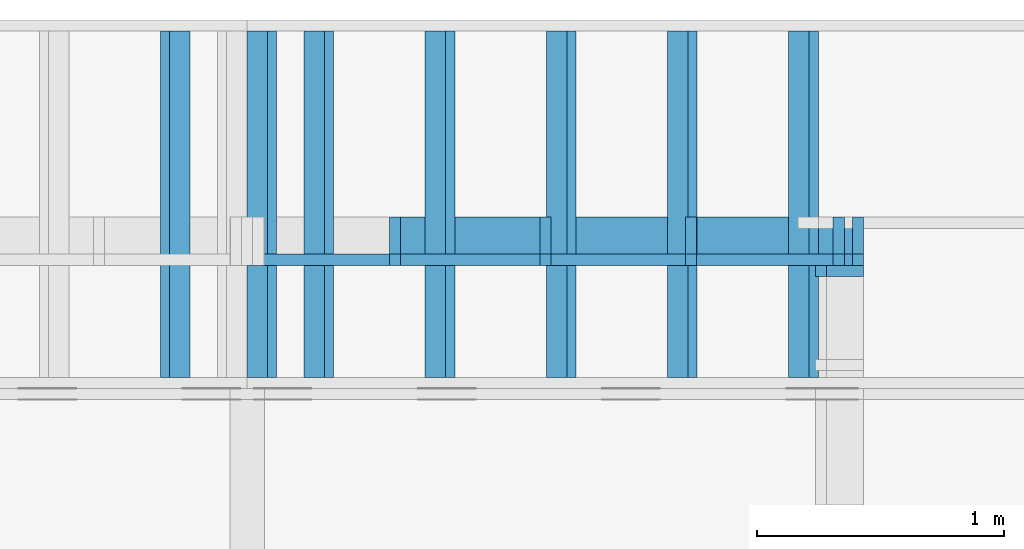
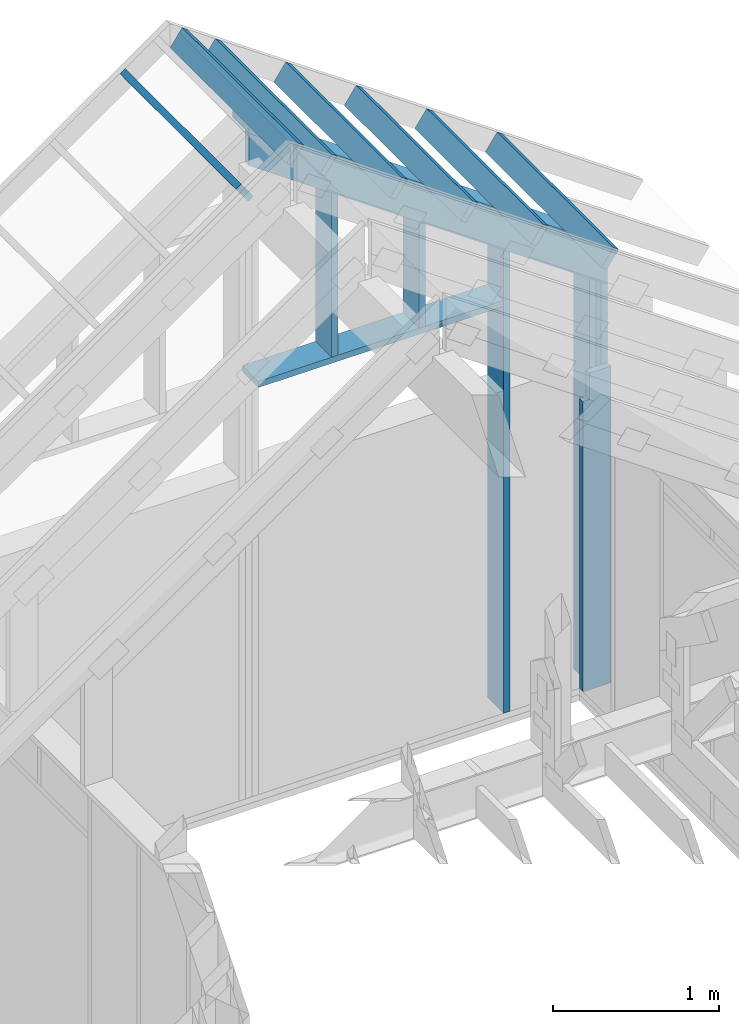
# One storey, part 35 of 70: 16 members, 4 elements without a shape of their own.
"""IFC2X3 building model written with IfcOpenShell, lengths in millimetres."""

from ifc_helpers import new_model, si_unit, frame, origin, origin_with_axes, origin_2d, place, context, project, spatial, faceted_brep, element, aggregate, save


model = new_model("IFC2X3")

# Units and contexts
model_context = context("Model", 3, precision=1e-05, world=origin())
plan_context = context("Plan", 2, precision=1e-05, world=origin_2d())
ifc_project = project(units=[si_unit("LENGTHUNIT", "METRE", prefix="MILLI"), si_unit("AREAUNIT", "SQUARE_METRE"), si_unit("VOLUMEUNIT", "CUBIC_METRE"), si_unit("SOLIDANGLEUNIT", "STERADIAN"), si_unit("PLANEANGLEUNIT", "RADIAN"), si_unit("MASSUNIT", "GRAM"), si_unit("TIMEUNIT", "SECOND"), si_unit("THERMODYNAMICTEMPERATUREUNIT", "DEGREE_CELSIUS"), si_unit("LUMINOUSINTENSITYUNIT", "LUMEN")], contexts=[model_context, plan_context])

# Site, building, storey
site_placement = place(None, origin_with_axes())
site = spatial("IfcSite", under=ifc_project, at=site_placement, CompositionType="ELEMENT")
building_placement = place(site_placement, origin_with_axes())
building = spatial("IfcBuilding", under=site, at=building_placement, Name="Layout 1", CompositionType="ELEMENT")
storey_placement = place(building_placement, origin_with_axes())
storey = spatial("IfcBuildingStorey", under=building, at=storey_placement, Name="Storey 1", CompositionType="ELEMENT", Elevation=0.0)

# Assembly, member
assembly_1_placement = place(storey_placement, frame((12000.0, 0.0, -2470.0), z_axis=(1.0, -6.123031769111886e-17, 6.123031769111886e-17), x_axis=(6.123031769111886e-17, 1.0, 0.0)))
assembly_1 = element("IfcElementAssembly", 1, at=assembly_1_placement, inside=storey, Name="VE5", AssemblyPlace="FACTORY", PredefinedType="NOTDEFINED")
member_1_placement = place(assembly_1_placement, frame((11760.0, 2425.0, -195.00000000000003), z_axis=(0.0, 0.0, 1.0), x_axis=(-1.836909530733566e-16, -1.0, 0.0)))
member_1 = element("IfcMember", 2, at=member_1_placement, Name="S11", context=model_context, shape_type="Brep", body=[
    faceted_brep([(0.0, 45.0, 45.00000000000003), (195.00000000186265, 45.0, 45.00000000000005), (195.00000000186265, 0.0, 45.00000000000005), (0.0, 0.0, 45.00000000000003), (195.00000000186265, -2.1311460639909362e-46, 2.842170943040401e-14), (195.00000000186265, -3.3742366240998114e-31, 45.00000000000003), (195.00000000186265, 45.0, 45.00000000000003), (195.00000000186265, 45.0, 2.842170943040401e-14), (2.7553642961003504e-15, -3.3742366240998114e-31, 45.00000000000003), (1.193991194976818e-14, -1.4621692037765842e-30, 195.00000000000003), (1.7450640541968876e-14, 45.0, 195.00000000000003), (8.266092888301048e-15, 45.0, 45.00000000000003), (2335.0, -4.2891837542628763e-13, 2.842170943040403e-14), (2335.0, -4.1697846347651946e-13, 195.00000000000003), (2.1932538056648764e-30, 1.193991194976818e-14, 195.00000000000003), (5.061354936149717e-31, 2.7553642961003504e-15, 45.00000000000003), (195.00000000186265, -3.306437155354634e-14, 45.00000000000003), (195.00000000186265, -3.5819735849646686e-14, 2.842170943040401e-14), (-1.6871183120499057e-31, 45.0, 45.00000000000003), (-7.310846018882921e-31, 44.999999999999986, 195.00000000000003), (2335.0, 44.999999999999844, 195.00000000000003), (2335.0, 44.99999999999986, 2.8421709430403998e-14), (195.00000000186265, 44.999999999999986, 2.842170943040401e-14), (195.00000000186265, 44.999999999999986, 45.00000000000003), (2335.0, 45.0, 0.0), (2335.0, 45.0, 195.00000000000003), (2335.0, 0.0, 195.00000000000003), (2335.0, 0.0, 0.0), (2335.0, 45.0, 195.00000000000003), (0.0, 45.0, 195.00000000000003), (0.0, 0.0, 195.00000000000003), (2335.0, 0.0, 195.00000000000003), (195.00000000186265, 45.0, 5.2301533330168465e-14), (2335.0, 45.0, 3.143672930479291e-13), (2335.0, 0.0, 3.143672930479291e-13), (195.00000000186265, 0.0, 5.2301533330168465e-14)], [[[0, 1, 2, 3]], [[4, 5, 6, 7]], [[8, 9, 10, 11]], [[12, 13, 14, 15, 16, 17]], [[18, 19, 20, 21, 22, 23]], [[24, 25, 26, 27]], [[28, 29, 30, 31]], [[32, 33, 34, 35]]]),
])
aggregate(assembly_1, [member_1])

# Assembly, members
assembly_2_placement = place(storey_placement, frame((12000.0, 12000.0, -2470.0), z_axis=(1.2246063538223773e-16, 1.0, 6.123031769111886e-17), x_axis=(-1.0, 1.2246063538223773e-16, 0.0)))
assembly_2 = element("IfcElementAssembly", 3, at=assembly_2_placement, inside=storey, Name="VE6", AssemblyPlace="FACTORY", PredefinedType="NOTDEFINED")
member_2_placement = place(assembly_2_placement, frame((2.2737367544323206e-13, 3238.052828134969, -195.00000000000003), z_axis=(0.0, 0.0, 1.0), x_axis=(0.819152044288992, 0.5735764363510458, 0.0)))
member_2 = element("IfcMember", 4, at=member_2_placement, Name="P9", context=model_context, shape_type="Brep", body=[
    faceted_brep([(3083.445811122576, 44.99999999928377, 195.0), (31.509339219794356, 44.99999999928377, 195.0), (0.0, 0.0, 195.0), (3051.9364719038495, 0.0, 195.0), (31.509339219794356, 44.99999999928377, 3.858653701330479e-15), (3083.445811122576, 44.99999999928377, 3.7760073319677e-13), (3051.9364719038495, 0.0, 3.7374207949557034e-13), (0.0, 0.0, 0.0), (2.9102126727628997e-15, -2.0377528512619995e-15, -2.175337872185383e-31), (1.269081595504608e-14, -8.886204997755278e-15, 195.0), (31.509339219794374, 45.00000000051067, 195.0), (31.509339219794363, 45.000000000510674, -4.7061727376910655e-31), (3051.9364719038495, 3.0032310338387844e-10, -9.515766024741373e-29), (3051.9364719038495, 3.003350432958282e-10, 195.0), (-1.1749364522806504e-27, 1.1939911949768178e-14, 195.0), (0.0, 0.0, 0.0), (3083.4458111225767, 44.99999999928332, 6.161406544749075e-29), (3083.4458111225767, 44.99999999928332, 195.0), (3051.9364719038504, 2.9831426218152046e-10, 195.0), (3051.9364719038504, 2.9831426218152046e-10, 6.127550325513703e-29), (31.509339219794356, 45.00000000051069, 3.944304526105059e-31), (31.509339219794356, 45.00000000051068, 195.0), (3083.445811122576, 44.9999999992846, 195.0), (3083.445811122576, 44.999999999284604, 5.088152838675526e-29)], [[[0, 1, 2, 3]], [[4, 5, 6, 7]], [[8, 9, 10, 11]], [[12, 13, 14, 15]], [[16, 17, 18, 19]], [[20, 21, 22, 23]]]),
])
member_3_placement = place(assembly_2_placement, frame((45.00000000000001, 90.00000000000031, -195.00000000000003), z_axis=(0.0, 0.0, 1.0), x_axis=(6.123031769111886e-17, 1.0, 0.0)))
member_3 = element("IfcMember", 5, at=member_3_placement, Name="S5", context=model_context, shape_type="Brep", body=[
    faceted_brep([(2910.0017833264797, 44.99999999999977, 2.842170943040401e-14), (2910.0017833264797, 44.99999999999977, 45.00000000000003), (2941.511122545937, 9.322320693172514e-12, 45.00000000000003), (2941.511122545937, 9.322320693172514e-12, 2.8421709430403982e-14), (2910.0017833264797, 45.000000000000185, 45.000000000000384), (3148.0528281349684, 45.000000000000185, 45.00000000000041), (3179.562167354859, 1.8474111129762605e-13, 45.00000000000042), (2941.5111225459227, 1.8474111129762605e-13, 45.00000000000039), (1.4210854715202004e-13, 45.0000000000002, 2.842170943040401e-14), (1.4210854715202004e-13, 45.000000000000185, 195.00000000000003), (3148.0528281349684, 44.99999999999999, 195.00000000000003), (3148.0528281349684, 45.0, 45.00000000000003), (2910.0017833264797, 45.00000000000002, 45.00000000000003), (2910.0017833264797, 45.00000000000002, 2.8421709430403998e-14), (1.4210854715202004e-13, 45.00000000000001, 2.8421709430404026e-14), (2910.0017833264797, 45.00000000000001, 3.847823767800096e-13), (2941.511122545923, 1.8474111129762605e-13, 3.886410304812971e-13), (1.4210854715202004e-13, 1.8474111129762605e-13, 2.8421709430404026e-14), (1.5631940186722204e-13, 0.0, 0.0), (2.9815540769813353e-13, 4.235455509100364e-28, 195.00000000000003), (1.6377803518756448e-13, 45.000000000000014, 195.00000000000003), (2.1942029356652964e-14, 45.000000000000014, -1.595984514755006e-29), (3179.562167354859, -3.9656032928367493e-13, 45.00000000000003), (3179.562167354859, -3.873757816300071e-13, 195.00000000000003), (1.4210854715202004e-13, 1.966810232473942e-13, 195.00000000000003), (1.4210854715202004e-13, 1.8474111129762602e-13, 2.842170943040401e-14), (2941.5111225459227, -3.5558787027871346e-13, 2.842170943040404e-14), (2941.5111225459227, -3.528325059826131e-13, 45.00000000000003), (3148.0528281349625, 44.99999999999591, 45.00000000000003), (3148.0528281349625, 44.99999999999591, 195.00000000000003), (3179.562167354859, 2.2737367544323206e-13, 195.00000000000003), (3179.562167354859, 2.2737367544323206e-13, 45.00000000000003), (3148.0528281349684, 45.0000000000002, 195.00000000000003), (1.4210854715202004e-13, 45.0000000000002, 195.00000000000003), (1.4210854715202004e-13, 7.105427357601002e-15, 195.00000000000003), (3179.562167354859, 7.105427357601002e-15, 195.00000000000003)], [[[0, 1, 2, 3]], [[4, 5, 6, 7]], [[8, 9, 10, 11, 12, 13]], [[14, 15, 16, 17]], [[18, 19, 20, 21]], [[22, 23, 24, 25, 26, 27]], [[28, 29, 30, 31]], [[32, 33, 34, 35]]]),
])
member_4_placement = place(assembly_2_placement, frame((122.50000000003187, 90.0, -195.00000000000003), z_axis=(0.0, 0.0, 1.0), x_axis=(2.8327492261615017e-16, 1.0, 0.0)))
member_4 = element("IfcMember", 6, at=member_4_placement, Name="S4", context=model_context, shape_type="Brep", body=[
    faceted_brep([(2964.2678675377542, 45.00000000001796, 2.8421709430403998e-14), (2964.2678675377542, 45.00000000001796, 45.00000000000003), (2995.7772067571723, -2.2737367544323206e-13, 45.00000000000003), (2995.7772067571723, -2.2737367544323206e-13, 2.8421709430403998e-14), (2964.2678675377542, 45.00000000001816, 45.00000000000039), (3202.3189123462435, 45.00000000001816, 45.00000000000042), (3233.828251565683, 1.8175683180743363e-11, 45.000000000000426), (2995.7772067571977, 1.8175683180743363e-11, 45.0000000000004), (-1.0655730319954681e-46, 45.00000000001823, 2.842170943040401e-14), (-7.310846018882921e-31, 45.00000000001822, 195.00000000000003), (3202.3189123462435, 45.00000000001803, 195.00000000000003), (3202.3189123462435, 45.000000000018034, 45.00000000000003), (2964.2678675377542, 45.00000000001805, 45.00000000000003), (2964.2678675377542, 45.00000000001805, 2.8421709430403998e-14), (0.0, 45.00000000001732, 2.842170943040401e-14), (2964.2678675377542, 45.00000000001732, 3.914278359322283e-13), (2995.777206757198, 1.8175683180743363e-11, 3.9528648963351586e-13), (0.0, 1.8175683180743363e-11, 2.842170943040401e-14), (2.1213894929551854e-27, 1.7323031897831243e-11, -1.2989335260024756e-43), (1.1939911949770302e-14, 1.7323031897831243e-11, 195.00000000000003), (1.7450640541971e-14, 45.00000000001732, 195.00000000000003), (5.510728592202819e-15, 45.00000000001732, -3.374236624101108e-31), (3233.828251565683, 1.7763251475369794e-11, 45.00000000000003), (3233.828251565683, 1.7772436023023462e-11, 195.00000000000003), (3.5044162499125324e-29, 1.836646101662911e-11, 195.00000000000003), (3.285090869346045e-29, 1.835452110467934e-11, 2.8421709430403995e-14), (2995.7772067571977, 1.7804223934374674e-11, 2.842170943040403e-14), (2995.7772067571977, 1.7806979298670775e-11, 45.00000000000003), (3202.3189123462807, 45.000000000044565, 45.00000000000003), (3202.3189123462807, 45.000000000044565, 195.00000000000003), (3233.828251565683, 1.8189894035458565e-11, 195.00000000000003), (3233.828251565683, 1.8189894035458565e-11, 45.00000000000003), (3202.3189123462435, 45.00000000001823, 195.00000000000003), (0.0, 45.00000000001823, 195.00000000000003), (0.0, 1.7323031897831243e-11, 195.00000000000003), (3233.828251565683, 1.7323031897831243e-11, 195.00000000000003)], [[[0, 1, 2, 3]], [[4, 5, 6, 7]], [[8, 9, 10, 11, 12, 13]], [[14, 15, 16, 17]], [[18, 19, 20, 21]], [[22, 23, 24, 25, 26, 27]], [[28, 29, 30, 31]], [[32, 33, 34, 35]]]),
])
member_5_placement = place(assembly_2_placement, frame((722.4999999994066, 90.0, -195.00000000000003), z_axis=(0.0, 0.0, 1.0), x_axis=(6.123031769111886e-17, 1.0, 0.0)))
member_5 = element("IfcMember", 7, at=member_5_placement, Name="S2/", context=model_context, shape_type="Brep", body=[
    faceted_brep([(3384.3923904632275, 45.00000000001819, 2.842170943040403e-14), (3384.3923904632275, 45.00000000001819, 45.00000000000003), (3415.9017296826455, 0.0, 45.00000000000003), (3415.9017296826455, 0.0, 2.842170943040401e-14), (3384.3923904632275, 45.00000000001796, 45.00000000000044), (3622.4434352717144, 45.00000000001796, 45.00000000000047), (3653.952774491161, 1.7962520360015333e-11, 45.000000000000476), (3415.901729682671, 1.7962520360015333e-11, 45.00000000000045), (4.547473508864641e-13, 45.00000000001796, 2.842170943040401e-14), (4.547473508864641e-13, 45.00000000001795, 195.00000000000003), (3622.4434352717144, 45.00000000001773, 195.00000000000003), (3622.4434352717144, 45.000000000017735, 45.00000000000003), (3384.3923904632275, 45.00000000001775, 45.00000000000003), (3384.3923904632275, 45.00000000001776, 2.8421709430403995e-14), (4.547473508864641e-13, 45.000000000017735, 2.8421709430404064e-14), (3384.3923904632275, 45.000000000017735, 4.4287655194934124e-13), (3415.901729682671, 1.7962520360015333e-11, 4.4673520565062877e-13), (0.0, 1.7962520360015333e-11, 2.842170943040401e-14), (-3.778888611581315e-27, 1.77351466845721e-11, 2.3138255020647436e-43), (1.1939911949764401e-14, 1.77351466845721e-11, 195.00000000000003), (4.570989582935271e-13, 45.000000000017735, 195.00000000000003), (4.451590463437589e-13, 45.000000000017735, 5.870949332690355e-31), (3653.952774491161, 1.7294077656680116e-11, 45.00000000000003), (3653.952774491161, 1.7303262204333784e-11, 195.00000000000003), (2.1932538056648764e-30, 1.79744602719651e-11, 195.00000000000003), (3.196719095986404e-46, 1.7962520360015333e-11, 2.8421709430404004e-14), (3415.901729682671, 1.7335050115684996e-11, 2.8421709430404045e-14), (3415.901729682671, 1.7337805479981096e-11, 45.00000000000003), (3622.4434352716885, 44.99999999999977, 45.00000000000003), (3622.4434352716885, 44.99999999999977, 195.00000000000003), (3653.952774491162, 1.77351466845721e-11, 195.00000000000003), (3653.952774491162, 1.77351466845721e-11, 45.00000000000003), (3622.4434352717144, 45.00000000001796, 195.00000000000003), (4.547473508864641e-13, 45.00000000001796, 195.00000000000003), (0.0, 1.77351466845721e-11, 195.00000000000003), (3653.952774491161, 1.77351466845721e-11, 195.00000000000003)], [[[0, 1, 2, 3]], [[4, 5, 6, 7]], [[8, 9, 10, 11, 12, 13]], [[14, 15, 16, 17]], [[18, 19, 20, 21]], [[22, 23, 24, 25, 26, 27]], [[28, 29, 30, 31]], [[32, 33, 34, 35]]]),
])
member_6_placement = place(assembly_2_placement, frame((1267.5000000034395, 4157.07522203782, -195.00000000000003), z_axis=(0.0, 0.0, 1.0), x_axis=(-1.836909530733566e-16, -1.0, 0.0)))
member_6 = element("IfcMember", 8, at=member_6_placement, Name="S29", context=model_context, shape_type="Brep", body=[
    faceted_brep([(0.0, 45.00000000000932, 45.00000000000003), (238.05104480853743, 45.00000000000932, 45.00000000000006), (269.56038402798094, 9.322320693172514e-12, 45.000000000000064), (31.5093392194467, 9.322320693172514e-12, 45.000000000000036), (269.5603840279655, 2.0037305148434825e-12, 2.842170943040401e-14), (269.5603840279655, 2.0037305148434825e-12, 45.00000000000003), (238.0510448085374, 45.00000000001269, 45.00000000000003), (238.0510448085374, 45.00000000001269, 2.842170943040401e-14), (31.50933921943396, -5.329070518200751e-15, 45.00000000000003), (31.509339219433972, 0.0, 195.00000000000003), (2.1316282072803006e-14, 45.00000000000934, 195.00000000000003), (1.4210854715202004e-14, 45.00000000000933, 45.00000000000003), (1022.075222037834, 9.134574721523722e-12, 2.8421709430404004e-14), (1022.075222037834, 9.14651463347349e-12, 195.00000000000003), (31.5093392194467, 9.32847262457035e-12, 195.00000000000003), (31.5093392194467, 9.319288076916683e-12, 45.00000000000003), (269.56038402798094, 9.275560253615696e-12, 45.00000000000003), (269.56038402798094, 9.272804889319595e-12, 2.8421709430404014e-14), (-1.6871183120499057e-31, 45.00000000001273, 45.00000000000003), (-7.310846018882921e-31, 45.00000000001272, 195.00000000000003), (1022.075222037834, 45.00000000001266, 195.00000000000003), (1022.075222037834, 45.00000000001267, 2.842170943040402e-14), (238.05104480853743, 45.00000000001272, 2.842170943040401e-14), (238.05104480853743, 45.00000000001272, 45.00000000000003), (1022.075222037834, 45.000000000023874, 0.0), (1022.075222037834, 45.000000000023874, 195.00000000000003), (1022.075222037834, 2.3874235921539366e-11, 195.00000000000003), (1022.075222037834, 2.3874235921539366e-11, 0.0), (1022.075222037834, 45.000000000023874, 195.00000000000003), (0.0, 45.000000000023874, 195.00000000000003), (31.5093392194467, 9.322320693172514e-12, 195.00000000000003), (1022.075222037834, 9.322320693172514e-12, 195.00000000000003), (238.05104480853743, 45.00000000001273, 5.757359163106304e-14), (1022.075222037834, 45.00000000001273, 1.5358569052959886e-13), (1022.075222037834, 2.3874235921539366e-11, 1.5358569052959886e-13), (269.56038402798094, 2.3874235921539366e-11, 6.143224533235056e-14)], [[[0, 1, 2, 3]], [[4, 5, 6, 7]], [[8, 9, 10, 11]], [[12, 13, 14, 15, 16, 17]], [[18, 19, 20, 21, 22, 23]], [[24, 25, 26, 27]], [[28, 29, 30, 31]], [[32, 33, 34, 35]]]),
])
member_7_placement = place(assembly_2_placement, frame((2432.4999999993743, 3134.9999999999854, -195.0), z_axis=(0.0, 0.0, 1.0), x_axis=(-1.0, 1.2246063538223773e-16, 0.0)))
member_7 = element("IfcMember", 9, at=member_7_placement, Name="S18", context=model_context, shape_type="Brep", body=[
    faceted_brep([(1709.9999999999854, 44.9999999999859, 195.0), (0.0, 44.9999999999859, 195.0), (0.0, 0.0, 195.0), (1709.9999999999854, 0.0, 195.0), (0.0, 44.9999999999859, 0.0), (1709.9999999999854, 44.9999999999859, 2.0940768650362472e-13), (1709.9999999999854, 0.0, 2.0940768650362472e-13), (0.0, 0.0, 0.0), (0.0, 0.0, 0.0), (1.1939911949768178e-14, -1.462169203776584e-30, 195.0), (1.7450640541967093e-14, 44.99999999998545, 195.0), (5.510728592198916e-15, 44.99999999998545, -3.374236624098718e-31), (1709.9999999999854, -3.141115297554371e-13, 4.707747352134165e-29), (1709.9999999999854, -3.021716178056689e-13, 195.0), (2.193253805664876e-30, 1.1939911949768178e-14, 195.0), (0.0, 0.0, 0.0), (1709.9999999999854, 44.9999999999859, 0.0), (1709.9999999999854, 44.9999999999859, 195.0), (1709.9999999999854, 4.547473508864641e-13, 195.0), (1709.9999999999854, 4.547473508864641e-13, 0.0), (0.0, 44.99999999998545, 0.0), (1.5777218104420236e-30, 44.999999999985434, 195.0), (1709.9999999999854, 44.99999999998571, 195.0), (1709.9999999999854, 44.999999999985725, -1.1044052673094165e-29)], [[[0, 1, 2, 3]], [[4, 5, 6, 7]], [[8, 9, 10, 11]], [[12, 13, 14, 15]], [[16, 17, 18, 19]], [[20, 21, 22, 23]]]),
])
member_8_placement = place(assembly_2_placement, frame((1922.4999999994034, 3134.9999999999854, -195.00000000000003), z_axis=(0.0, 0.0, 1.0), x_axis=(6.123031769111886e-17, 1.0, 0.0)))
member_8 = element("IfcMember", 10, at=member_8_placement, Name="S19/", context=model_context, shape_type="Brep", body=[
    faceted_brep([(1179.6414363150782, 45.000000000012164, 2.842170943040403e-14), (1179.6414363150782, 45.000000000012164, 45.00000000000003), (1211.1507755345358, 2.1941559680271894e-11, 45.00000000000003), (1211.1507755345358, 2.1941559680271894e-11, 2.842170943040402e-14), (1179.641436315078, 45.00000000001205, 45.00000000000017), (1417.6924811235513, 45.00000000001205, 45.0000000000002), (1449.201820342998, 1.2278178473934531e-11, 45.000000000000206), (1211.150775534521, 1.2278178473934531e-11, 45.00000000000018), (-1.0655730319954681e-46, 45.00000000001455, 2.842170943040401e-14), (-7.310846018882921e-31, 45.00000000001454, 195.00000000000003), (1417.6924811235513, 45.00000000001445, 195.00000000000003), (1417.6924811235513, 45.00000000001446, 45.00000000000003), (1179.641436315078, 45.000000000014474, 45.00000000000003), (1179.641436315078, 45.00000000001448, 2.8421709430404e-14), (0.0, 45.0, 2.842170943040401e-14), (1179.641436315078, 45.0, 1.7288134924476397e-13), (1211.150775534521, 1.2050804798491299e-11, 1.7674000294605142e-13), (0.0, 1.2050804798491299e-11, 2.842170943040401e-14), (0.0, 0.0, 0.0), (1.193991194976818e-14, -1.4621692037765842e-30, 195.00000000000003), (1.7450640541968876e-14, 45.0, 195.00000000000003), (5.510728592200698e-15, 45.0, -3.3742366240998092e-31), (1449.201820342998, 1.2014728574656183e-11, 45.00000000000003), (1449.201820342998, 1.202391312230985e-11, 195.00000000000003), (2.1932538056648764e-30, 1.22901183858843e-11, 195.00000000000003), (3.1967190959864043e-46, 1.2278178473934531e-11, 2.842170943040401e-14), (1211.150775534521, 1.205570103366106e-11, 2.842170943040402e-14), (1211.150775534521, 1.205845639795716e-11, 45.00000000000003), (1417.6924811235542, 45.000000000016826, 45.00000000000003), (1417.6924811235542, 45.000000000016826, 195.00000000000003), (1449.2018203429982, 1.4779288903810084e-11, 195.00000000000003), (1449.2018203429982, 1.4779288903810084e-11, 45.00000000000003), (1417.6924811235513, 45.00000000001455, 195.00000000000003), (0.0, 45.00000000001455, 195.00000000000003), (0.0, 0.0, 195.00000000000003), (1449.201820342998, 0.0, 195.00000000000003)], [[[0, 1, 2, 3]], [[4, 5, 6, 7]], [[8, 9, 10, 11, 12, 13]], [[14, 15, 16, 17]], [[18, 19, 20, 21]], [[22, 23, 24, 25, 26, 27]], [[28, 29, 30, 31]], [[32, 33, 34, 35]]]),
])
member_9_placement = place(assembly_2_placement, frame((0.0, 3000.001783326472, -195.0), z_axis=(0.0, 0.0, 1.0), x_axis=(0.819152044288936, 0.5735764363511259, 0.0)))
member_9 = element("IfcMember", 11, at=member_9_placement, Name="L6", context=model_context, shape_type="Brep", body=[
    faceted_brep([(3188.476941856388, 195.00000000000182, 45.0), (136.54046995091153, 195.00000000000182, 45.0), (0.0, 0.0, 45.0), (3051.9364719058435, 0.0, 45.0), (136.54046995091153, 195.00000000000182, 1.6720832705577965e-14), (3188.476941856388, 195.00000000000182, 3.904629122013475e-13), (3051.9364719058435, 0.0, 3.737420794958145e-13), (0.0, 0.0, 0.0), (0.0, 0.0, 0.0), (2.257062295911346e-15, -1.5804120338063659e-15, 45.0), (136.54046995091147, 194.99999999998548, 45.0), (136.54046995091147, 194.99999999998548, 5.4114073596708955e-30), (3051.9364719058435, 6.283134610138181e-10, 9.255697061996014e-29), (3051.9364719058435, 6.283162163781142e-10, 45.0), (-5.6725704914677e-28, 2.755364296100349e-15, 45.0), (0.0, 0.0, 0.0), (3188.4769418563874, 195.00000000000227, -2.524354896707238e-29), (3188.4769418563874, 195.00000000000227, 45.0), (3051.936471905843, 6.30052454653196e-10, 45.0), (3051.936471905843, 6.30052454653196e-10, -2.524354896707238e-29), (136.54046995091153, 194.99999999998542, 0.0), (136.54046995091153, 194.99999999998542, 45.0), (3188.476941856388, 195.0000000000015, 45.0), (3188.476941856388, 195.0000000000015, -1.8932661725304283e-29)], [[[0, 1, 2, 3]], [[4, 5, 6, 7]], [[8, 9, 10, 11]], [[12, 13, 14, 15]], [[16, 17, 18, 19]], [[20, 21, 22, 23]]]),
])
aggregate(assembly_2, [member_2, member_3, member_4, member_5, member_6, member_7, member_8, member_9])

# Assembly, member
assembly_3_placement = place(storey_placement, frame((9499.999999999996, 12800.0, 2750.5188455242724), z_axis=(-0.5735764363510464, 8.131391261780321e-17, 0.8191520442889916), x_axis=(-0.8191520442889916, 1.3543414723620324e-16, -0.5735764363510464)))
assembly_3 = element("IfcElementAssembly", 12, at=assembly_3_placement, inside=storey, Name="gs4", AssemblyPlace="FACTORY", PredefinedType="TRUSS")
member_10_placement = place(assembly_3_placement, frame((383.55614291509875, 1449.9999999999982, -145.0), z_axis=(0.0, 0.0, 1.0), x_axis=(-1.836909530733566e-16, -1.0, 0.0)))
member_10 = element("IfcMember", 13, at=member_10_placement, Name="T14", context=model_context, shape_type="Brep", body=[
    faceted_brep([(1404.9999999999982, 45.0, 145.0), (0.0, 45.0, 145.0), (0.0, 1.4267698134062812e-11, 145.0), (1404.9999999999982, 1.4267698134062812e-11, 145.0), (0.0, 45.0, 0.0), (1404.9999999999982, 45.0, 1.7205719271204378e-13), (1404.9999999999982, 1.4267698134062812e-11, 1.7205719271204378e-13), (0.0, 1.4267698134062812e-11, 0.0), (1.7472313789392995e-27, 1.4267698134062812e-11, -1.06983532412345e-43), (8.878396065213982e-15, 1.4267698134062812e-11, 145.0), (1.438912465741468e-14, 45.00000000001427, 145.0), (5.510728592202445e-15, 45.00000000001427, -3.374236624100879e-31), (1404.9999999999982, 2.8281486852932803e-13, -1.7316844247822758e-29), (1404.9999999999982, 2.9169326459454027e-13, 145.0), (8.837247868837372e-29, 1.4276576530128024e-11, 145.0), (0.0, 1.4267698134062812e-11, 0.0), (1404.9999999999982, 45.0, 0.0), (1404.9999999999982, 45.0, 145.0), (1404.9999999999982, 0.0, 145.0), (1404.9999999999982, 0.0, 0.0), (0.0, 45.00000000001427, 0.0), (-1.0097419586828951e-28, 45.00000000001426, 145.0), (1404.9999999999982, 45.000000000000135, 145.0), (1404.9999999999982, 45.00000000000014, 8.67746995743113e-30)], [[[0, 1, 2, 3]], [[4, 5, 6, 7]], [[8, 9, 10, 11]], [[12, 13, 14, 15]], [[16, 17, 18, 19]], [[20, 21, 22, 23]]]),
])
aggregate(assembly_3, [member_10])

# Assembly, members
assembly_4_placement = place(storey_placement, frame((12800.0, 12799.999999999998, 439.8339694322314), z_axis=(0.5735764363510458, -3.1388626346160497e-16, 0.8191520442889919), x_axis=(-0.8191520442889919, 4.2897019649573644e-16, 0.5735764363510458)))
assembly_4 = element("IfcElementAssembly", 14, at=assembly_4_placement, inside=storey, Name="gs5", AssemblyPlace="FACTORY", PredefinedType="TRUSS")
member_11_placement = place(assembly_4_placement, frame((3882.0260498742573, 1449.9999999999984, -145.0), z_axis=(0.0, 0.0, 1.0), x_axis=(-1.836909530733566e-16, -1.0, 0.0)))
member_11 = element("IfcMember", 15, at=member_11_placement, Name="W2", context=model_context, shape_type="Brep", body=[
    faceted_brep([(1404.9999999999984, 45.000000000000455, 145.0), (0.0, 45.000000000000455, 145.0), (0.0, 0.0, 145.0), (1404.9999999999984, 0.0, 145.0), (0.0, 45.000000000000455, 0.0), (1404.9999999999984, 45.000000000000455, 1.720571927120438e-13), (1404.9999999999984, 0.0, 1.720571927120438e-13), (0.0, 0.0, 0.0), (0.0, 0.0, 0.0), (8.878396065212235e-15, -1.0872540233210496e-30, 145.0), (1.4389124657412933e-14, 45.0, 145.0), (5.510728592200698e-15, 45.0, -3.3742366240998092e-31), (1404.9999999999984, -2.580857890680657e-13, 4.364699962017366e-29), (1404.9999999999984, -2.4920739300285347e-13, 145.0), (1.6308810349815745e-30, 8.878396065212235e-15, 145.0), (0.0, 0.0, 0.0), (1404.9999999999984, 45.000000000000455, 0.0), (1404.9999999999984, 45.000000000000455, 145.0), (1404.9999999999984, 4.547473508864641e-13, 145.0), (1404.9999999999984, 4.547473508864641e-13, 0.0), (0.0, 45.0, 0.0), (3.1554436208840472e-30, 44.99999999999999, 145.0), (1404.9999999999984, 45.000000000000526, 145.0), (1404.9999999999984, 45.00000000000054, 5.127595883936577e-30)], [[[0, 1, 2, 3]], [[4, 5, 6, 7]], [[8, 9, 10, 11]], [[12, 13, 14, 15]], [[16, 17, 18, 19]], [[20, 21, 22, 23]]]),
])
member_12_placement = place(assembly_4_placement, frame((1244.9999999992142, 44.99999999999999, -145.0), z_axis=(0.0, 0.0, 1.0), x_axis=(6.123031769111886e-17, 1.0, 0.0)))
member_12 = element("IfcMember", 16, at=member_12_placement, Name="W2", context=model_context, shape_type="Brep", body=[
    faceted_brep([(1404.9999999999984, 45.0, 145.0), (0.0, 45.0, 145.0), (7.105427357601002e-15, 0.0, 145.0), (1404.9999999999984, 0.0, 145.0), (0.0, 45.0, 0.0), (1404.9999999999984, 45.0, 1.720571927120438e-13), (1404.9999999999984, 0.0, 1.720571927120438e-13), (7.105427357601002e-15, 0.0, 8.701351488741532e-31), (7.105427357601002e-15, 0.0, 0.0), (1.5983823422813237e-14, -1.0872540233210496e-30, 145.0), (2.1494552015013935e-14, 45.0, 145.0), (1.26161559498017e-14, 45.0, -7.724912368470575e-31), (1404.9999999999984, -2.580857890680657e-13, 1.5802674856200756e-29), (1404.9999999999984, -2.4920739300285347e-13, 145.0), (7.105427357601003e-15, 8.878396065212234e-15, 145.0), (7.105427357601002e-15, -1.3052027233112297e-30, 7.991797739966011e-47), (1404.9999999999984, 45.0, 0.0), (1404.9999999999984, 45.0, 145.0), (1404.9999999999984, 0.0, 145.0), (1404.9999999999984, 0.0, 0.0), (0.0, 45.0, 0.0), (-5.436270116605248e-31, 44.99999999999999, 145.0), (1404.9999999999984, 44.99999999999991, 145.0), (1404.9999999999984, 44.999999999999915, -5.127595883936577e-30)], [[[0, 1, 2, 3]], [[4, 5, 6, 7]], [[8, 9, 10, 11]], [[12, 13, 14, 15]], [[16, 17, 18, 19]], [[20, 21, 22, 23]]]),
])
member_13_placement = place(assembly_4_placement, frame((1844.9999999992287, 45.0, -145.0), z_axis=(0.0, 0.0, 1.0), x_axis=(6.123031769111886e-17, 1.0, 0.0)))
member_13 = element("IfcMember", 17, at=member_13_placement, Name="W2", context=model_context, shape_type="Brep", body=[
    faceted_brep([(1404.9999999999982, 45.00000000001455, 145.0), (0.0, 45.00000000001455, 145.0), (0.0, 1.4551915228366852e-11, 145.0), (1404.9999999999982, 1.4551915228366852e-11, 145.0), (0.0, 45.00000000001455, 0.0), (1404.9999999999982, 45.00000000001455, 1.7205719271204378e-13), (1404.9999999999982, 1.4551915228366852e-11, 1.7205719271204378e-13), (0.0, 1.4551915228366852e-11, 0.0), (1.7820367848942657e-27, 1.4551915228366852e-11, -1.0911467847633593e-43), (8.878396065214018e-15, 1.4551915228366852e-11, 145.0), (1.4389124657414716e-14, 45.00000000001455, 145.0), (5.51072859220248e-15, 45.00000000001455, -3.3742366241009005e-31), (1404.9999999999982, 5.670319628333681e-13, -3.471954722530582e-29), (1404.9999999999982, 5.759103588985803e-13, 145.0), (8.837247868837372e-29, 1.4560793624432064e-11, 145.0), (0.0, 1.4551915228366852e-11, 0.0), (1404.9999999999982, 45.00000000001455, 0.0), (1404.9999999999982, 45.00000000001455, 145.0), (1404.9999999999982, 0.0, 145.0), (1404.9999999999982, 0.0, 0.0), (-1.2154326714572542e-63, 45.00000000001455, 0.0), (-5.436270116605248e-31, 45.000000000014545, 145.0), (1404.9999999999982, 45.00000000001446, 145.0), (1404.9999999999982, 45.00000000001447, -5.127595883936577e-30)], [[[0, 1, 2, 3]], [[4, 5, 6, 7]], [[8, 9, 10, 11]], [[12, 13, 14, 15]], [[16, 17, 18, 19]], [[20, 21, 22, 23]]]),
])
member_14_placement = place(assembly_4_placement, frame((2444.999999999214, 45.0, -145.0), z_axis=(0.0, 0.0, 1.0), x_axis=(6.123031769111886e-17, 1.0, 0.0)))
member_14 = element("IfcMember", 18, at=member_14_placement, Name="W2", context=model_context, shape_type="Brep", body=[
    faceted_brep([(1404.9999999999984, 44.99999999998545, 145.0), (0.0, 44.99999999998545, 145.0), (0.0, 0.0, 145.0), (1404.9999999999984, 0.0, 145.0), (0.0, 44.99999999998545, 0.0), (1404.9999999999984, 44.99999999998545, 1.720571927120438e-13), (1404.9999999999984, 0.0, 1.720571927120438e-13), (0.0, 0.0, 0.0), (0.0, 0.0, 0.0), (8.878396065212235e-15, -1.0872540233210496e-30, 145.0), (1.4389124657412933e-14, 45.0, 145.0), (5.510728592200698e-15, 45.0, -3.3742366240998092e-31), (1404.9999999999984, 1.3468711687397355e-11, 6.632489693770719e-29), (1404.9999999999984, 1.3477590083462567e-11, 145.0), (-8.511071661841057e-29, 8.878396065212235e-15, 145.0), (0.0, 0.0, 0.0), (1404.9999999999984, 44.99999999998545, 0.0), (1404.9999999999984, 44.99999999998545, 145.0), (1404.9999999999984, 1.4551915228366852e-11, 145.0), (1404.9999999999984, 1.4551915228366852e-11, 0.0), (0.0, 45.0, 0.0), (-1.0097419586828951e-28, 44.99999999999999, 145.0), (1404.9999999999984, 44.999999999985555, 145.0), (1404.9999999999984, 44.99999999998556, 7.099748146989106e-30)], [[[0, 1, 2, 3]], [[4, 5, 6, 7]], [[8, 9, 10, 11]], [[12, 13, 14, 15]], [[16, 17, 18, 19]], [[20, 21, 22, 23]]]),
])
member_15_placement = place(assembly_4_placement, frame((3044.9999999992287, 45.0, -145.0), z_axis=(0.0, 0.0, 1.0), x_axis=(6.123031769111886e-17, 1.0, 0.0)))
member_15 = element("IfcMember", 19, at=member_15_placement, Name="W2", context=model_context, shape_type="Brep", body=[
    faceted_brep([(1404.9999999999984, 45.00000000001455, 145.0), (0.0, 45.00000000001455, 145.0), (0.0, 1.4551915228366852e-11, 145.0), (1404.9999999999984, 1.4551915228366852e-11, 145.0), (0.0, 45.00000000001455, 0.0), (1404.9999999999984, 45.00000000001455, 1.720571927120438e-13), (1404.9999999999984, 1.4551915228366852e-11, 1.720571927120438e-13), (0.0, 1.4551915228366852e-11, 0.0), (1.7820367848942657e-27, 1.4551915228366852e-11, -1.0911467847633593e-43), (8.878396065214018e-15, 1.4551915228366852e-11, 145.0), (1.4389124657414716e-14, 45.00000000001455, 145.0), (5.51072859220248e-15, 45.00000000001455, -3.3742366241009005e-31), (1404.9999999999984, 5.670319628333665e-13, -3.471954722530564e-29), (1404.9999999999984, 5.759103588985787e-13, 145.0), (8.837247868837372e-29, 1.4560793624432064e-11, 145.0), (0.0, 1.4551915228366852e-11, 0.0), (1404.9999999999984, 45.00000000001455, 0.0), (1404.9999999999984, 45.00000000001455, 145.0), (1404.9999999999984, 0.0, 145.0), (1404.9999999999984, 0.0, 0.0), (-1.2154326714572542e-63, 45.00000000001455, 0.0), (-5.436270116605248e-31, 45.000000000014545, 145.0), (1404.9999999999984, 45.00000000001446, 145.0), (1404.9999999999984, 45.00000000001447, -5.127595883936577e-30)], [[[0, 1, 2, 3]], [[4, 5, 6, 7]], [[8, 9, 10, 11]], [[12, 13, 14, 15]], [[16, 17, 18, 19]], [[20, 21, 22, 23]]]),
])
member_16_placement = place(assembly_4_placement, frame((3644.999999999214, 45.0, -145.0), z_axis=(0.0, 0.0, 1.0), x_axis=(6.123031769111886e-17, 1.0, 0.0)))
member_16 = element("IfcMember", 20, at=member_16_placement, Name="W2", context=model_context, shape_type="Brep", body=[
    faceted_brep([(1404.9999999999984, 45.0, 145.0), (0.0, 45.0, 145.0), (0.0, 0.0, 145.0), (1404.9999999999984, 0.0, 145.0), (0.0, 45.0, 0.0), (1404.9999999999984, 45.0, 1.720571927120438e-13), (1404.9999999999984, 0.0, 1.720571927120438e-13), (0.0, 0.0, 0.0), (0.0, 0.0, 0.0), (8.878396065212235e-15, -1.0872540233210496e-30, 145.0), (1.4389124657412933e-14, 45.0, 145.0), (5.510728592200698e-15, 45.0, -3.3742366240998092e-31), (1404.9999999999984, -2.580857890680657e-13, 1.5802674856200756e-29), (1404.9999999999984, -2.4920739300285347e-13, 145.0), (1.6308810349815745e-30, 8.878396065212235e-15, 145.0), (0.0, 0.0, 0.0), (1404.9999999999984, 45.0, 0.0), (1404.9999999999984, 45.0, 145.0), (1404.9999999999984, 0.0, 145.0), (1404.9999999999984, 0.0, 0.0), (0.0, 45.0, 0.0), (-5.436270116605248e-31, 44.99999999999999, 145.0), (1404.9999999999984, 44.99999999999991, 145.0), (1404.9999999999984, 44.999999999999915, -5.127595883936577e-30)], [[[0, 1, 2, 3]], [[4, 5, 6, 7]], [[8, 9, 10, 11]], [[12, 13, 14, 15]], [[16, 17, 18, 19]], [[20, 21, 22, 23]]]),
])
aggregate(assembly_4, [member_11, member_12, member_13, member_14, member_15, member_16])

save(model, "model.ifc")
